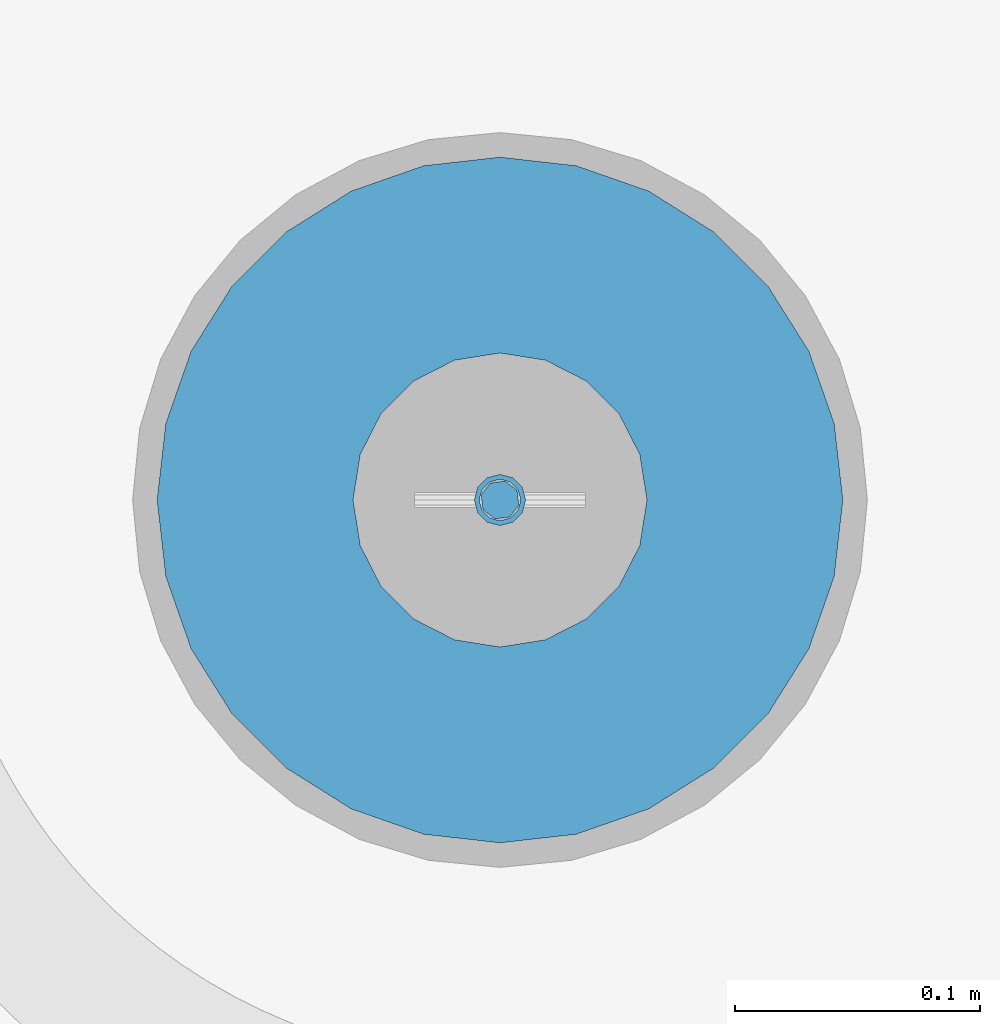
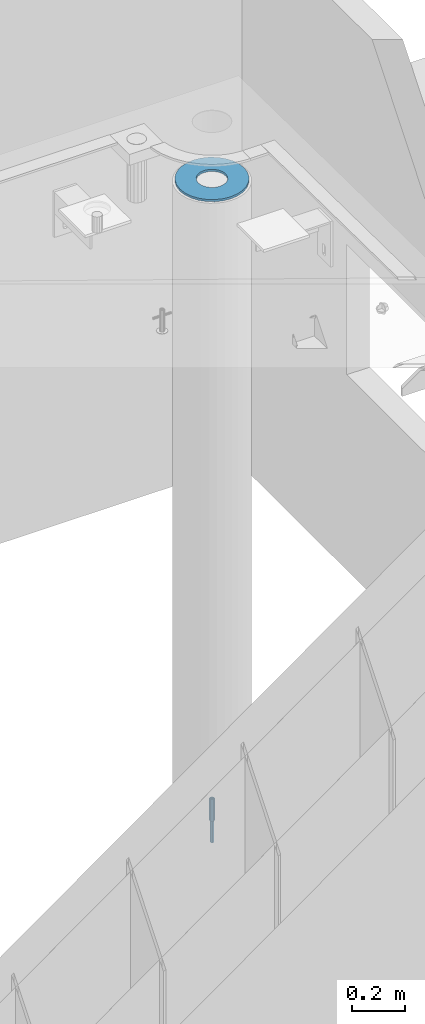
# One storey, part 23 of 264: 3 columns, 3 elements without a shape of their own.
"""IFC2X3 building model written with IfcOpenShell, lengths in millimetres."""

from ifc_helpers import new_model, si_unit, frame, origin_with_axes, place, context, subcontext, project, spatial, faceted_brep, material, type_object, element, aggregate, save


model = new_model("IFC2X3")

# Units and contexts
model_context = context("Model", 3, precision=1e-05, world=origin_with_axes())
body_context = subcontext(model_context, "Body", "Model", "MODEL_VIEW")
ifc_project = project(units=[si_unit("LENGTHUNIT", "METRE", prefix="MILLI"), si_unit("AREAUNIT", "SQUARE_METRE"), si_unit("VOLUMEUNIT", "CUBIC_METRE"), si_unit("MASSUNIT", "GRAM", prefix="KILO"), si_unit("TIMEUNIT", "SECOND"), si_unit("PLANEANGLEUNIT", "RADIAN"), si_unit("SOLIDANGLEUNIT", "STERADIAN"), si_unit("THERMODYNAMICTEMPERATUREUNIT", "DEGREE_CELSIUS"), si_unit("LUMINOUSINTENSITYUNIT", "LUMEN")], contexts=[model_context])

# Site, building, storey
site_placement = place(None, origin_with_axes())
site = spatial("IfcSite", under=ifc_project, at=site_placement, CompositionType="ELEMENT")
building_placement = place(site_placement, origin_with_axes())
building = spatial("IfcBuilding", under=site, at=building_placement, CompositionType="ELEMENT")
storey_placement = place(building_placement, origin_with_axes())
storey = spatial("IfcBuildingStorey", under=building, at=storey_placement, Name="K", CompositionType="ELEMENT", Elevation=0.0)

# Assemblies, columns
assembly_1_placement = place(storey_placement, origin_with_axes())
assembly_1 = element("IfcElementAssembly", 1, at=assembly_1_placement, inside=storey, AssemblyPlace="NOTDEFINED", PredefinedType="REINFORCEMENT_UNIT")
assembly_2_placement = place(assembly_1_placement, origin_with_axes())
assembly_2 = element("IfcElementAssembly", 2, at=assembly_2_placement, Name="Steel Assembly", AssemblyPlace="NOTDEFINED", PredefinedType="RIGID_FRAME")
ifc_material_1 = material(Name="STEEL/S235JR")
column_type_1 = type_object("IfcColumnType", Name="D16", PredefinedType="NOTDEFINED")
column_1_placement = place(assembly_2_placement, frame((35010.0004801435, 22669.9842012047, 78390.0), z_axis=(-0.261346946111888, -0.96524492941325, 0.0), x_axis=(0.0, 0.0, 1.0)))
column_1 = element("IfcColumn", 3, at=column_1_placement, type_object=column_type_1, material=ifc_material_1, Name="M16", ObjectType="D16", context=body_context, shape_type="Brep", body=[
    faceted_brep([(0.0, -8.0, 0.0), (0.0, -5.65685424949334, -5.65685424949334), (150.0, -5.65685424949697, -5.65685424949334), (150.0, -8.00000000000364, 0.0), (0.0, 0.0, -8.0), (150.0, -7.27595761418343e-12, -7.99999999999636), (0.0, 5.65685424949334, -5.65685424949334), (150.0, 5.6568542494897, -5.65685424949334), (0.0, 8.0, 0.0), (150.0, 8.0, -3.63797880709171e-12), (0.0, 5.65685424949334, 5.65685424949334), (150.0, 5.65685424949334, 5.65685424949697), (0.0, 0.0, 8.0), (150.0, -3.63797880709171e-12, 8.0), (0.0, -5.65685424949334, 5.65685424949334), (150.0, -5.65685424949334, 5.6568542494897)], [[[0, 1, 2, 3]], [[1, 4, 5, 2]], [[4, 6, 7, 5]], [[6, 8, 9, 7]], [[8, 10, 11, 9]], [[10, 12, 13, 11]], [[12, 14, 15, 13]], [[14, 0, 3, 15]], [[5, 7, 9, 11, 13, 15, 3, 2]], [[14, 12, 10, 8, 6, 4, 1, 0]]]),
])
aggregate(assembly_2, [column_1])
assembly_3_placement = place(assembly_1_placement, origin_with_axes())
assembly_3 = element("IfcElementAssembly", 4, at=assembly_3_placement, Name="Steel Assembly", AssemblyPlace="NOTDEFINED", PredefinedType="RIGID_FRAME")
ifc_material_2 = material(Name="STEEL/Steel_Undefined")
column_type_2 = type_object("IfcColumnType", PredefinedType="NOTDEFINED")
column_2_placement = place(assembly_3_placement, frame((35009.9987952044, 22669.984888838, 78490.0), z_axis=(0.0, 1.0, 0.0), x_axis=(0.0, 0.0, 1.0)))
column_2 = element("IfcColumn", 5, at=column_2_placement, type_object=column_type_2, material=ifc_material_2, context=body_context, shape_type="Brep", body=[
    faceted_brep([(0.0, -8.49999999999272, -1.45519152283669e-11), (0.0, -7.36121593215648, 4.24999999998545), (100.000000000262, -7.36121593215648, 4.24999999998545), (100.000000000262, -8.49999999999272, -1.45519152283669e-11), (0.0, -4.24999999998545, 7.36121593216376), (100.000000000262, -4.24999999998545, 7.36121593216376), (0.0, 1.45519152283669e-11, 8.49999999998545), (100.000000000262, 1.45519152283669e-11, 8.49999999998545), (0.0, 4.25000000001455, 7.36121593216376), (100.000000000262, 4.25000000001455, 7.36121593216376), (0.0, 7.36121593217104, 4.24999999998545), (100.000000000262, 7.36121593217104, 4.24999999998545), (0.0, 8.50000000000728, 0.0), (100.000000000262, 8.50000000000728, 0.0), (0.0, 7.36121593217104, -4.25000000001455), (100.000000000262, 7.36121593217104, -4.25000000001455), (0.0, 4.25000000000728, -7.36121593219286), (100.000000000262, 4.25000000000728, -7.36121593219286), (0.0, 7.27595761418343e-12, -8.5), (100.000000000262, 7.27595761418343e-12, -8.5), (0.0, -4.24999999999272, -7.36121593217831), (100.000000000262, -4.24999999999272, -7.36121593217831), (0.0, -7.36121593215648, -4.25), (100.000000000262, -7.36121593215648, -4.25), (0.0, -10.4999999999927, -1.45519152283669e-11), (0.0, -9.09326673972828, -5.25000000001455), (100.000000000262, -9.09326673972828, -5.25000000001455), (100.000000000262, -10.4999999999927, -1.45519152283669e-11), (0.0, -5.24999999998545, -9.09326673974283), (100.000000000262, -5.24999999998545, -9.09326673974283), (0.0, 7.27595761418343e-12, -10.5), (100.000000000262, 7.27595761418343e-12, -10.5), (0.0, 5.25000000001455, -9.09326673975738), (100.000000000262, 5.25000000001455, -9.09326673975738), (0.0, 9.09326673975011, -5.25000000001455), (100.000000000262, 9.09326673975011, -5.25000000001455), (0.0, 10.5000000000073, -1.45519152283669e-11), (100.000000000262, 10.5000000000073, -1.45519152283669e-11), (0.0, 9.09326673975011, 5.25), (100.000000000262, 9.09326673975011, 5.25), (0.0, 5.25000000000728, 9.09326673972828), (100.000000000262, 5.25000000000728, 9.09326673972828), (0.0, 1.45519152283669e-11, 10.4999999999854), (100.000000000262, 1.45519152283669e-11, 10.4999999999854), (0.0, -5.24999999999272, 9.09326673972828), (100.000000000262, -5.24999999999272, 9.09326673972828), (0.0, -9.09326673972828, 5.24999999998545), (100.000000000262, -9.09326673972828, 5.24999999998545)], [[[0, 1, 2, 3]], [[1, 4, 5, 2]], [[4, 6, 7, 5]], [[6, 8, 9, 7]], [[8, 10, 11, 9]], [[10, 12, 13, 11]], [[12, 14, 15, 13]], [[14, 16, 17, 15]], [[16, 18, 19, 17]], [[18, 20, 21, 19]], [[20, 22, 23, 21]], [[22, 0, 3, 23]], [[24, 25, 26, 27]], [[25, 28, 29, 26]], [[28, 30, 31, 29]], [[30, 32, 33, 31]], [[32, 34, 35, 33]], [[34, 36, 37, 35]], [[36, 38, 39, 37]], [[38, 40, 41, 39]], [[40, 42, 43, 41]], [[42, 44, 45, 43]], [[44, 46, 47, 45]], [[46, 24, 27, 47]], [[29, 31, 33, 35, 37, 39, 41, 43, 45, 47, 27, 26], [5, 7, 9, 11, 13, 15, 17, 19, 21, 23, 3, 2]], [[46, 44, 42, 40, 38, 36, 34, 32, 30, 28, 25, 24], [22, 20, 18, 16, 14, 12, 10, 8, 6, 4, 1, 0]]]),
])
aggregate(assembly_3, [column_2])
ifc_material_3 = material()
column_type_3 = type_object("IfcColumnType", Name="D280", PredefinedType="NOTDEFINED")
column_3_placement = place(assembly_1_placement, frame((35009.9987952044, 22669.984888838, 81435.0), z_axis=(-1.0, 3.00000001838171e-08, 0.0), x_axis=(0.0, 0.0, 1.0)))
column_3 = element("IfcColumn", 6, at=column_3_placement, type_object=column_type_3, material=ifc_material_3, Name="60", ObjectType="D280", context=body_context, shape_type="Brep", body=[
    faceted_brep([(10.0, -18.541019662498, -57.0633909777098), (0.0, -18.541019662498, -57.0633909777098), (0.0, -35.2671151375471, -48.5410196624944), (10.0, -35.2671151375471, -48.5410196624944), (0.0, -48.541019662498, -35.2671151375471), (10.0, -48.541019662498, -35.2671151375471), (0.0, -57.0633909777098, -18.5410196624944), (10.0, -57.0633909777098, -18.5410196624944), (0.0, -60.0, 0.0), (10.0, -60.0, 0.0), (0.0, -57.0633909777098, 18.5410196624944), (10.0, -57.0633909777098, 18.5410196624944), (0.0, -48.541019662498, 35.2671151375471), (10.0, -48.541019662498, 35.2671151375471), (0.0, -35.2671151375471, 48.5410196624944), (10.0, -35.2671151375471, 48.5410196624944), (0.0, -18.541019662498, 57.0633909777098), (10.0, -18.541019662498, 57.0633909777098), (0.0, 0.0, 60.0), (10.0, 0.0, 60.0), (0.0, 18.541019662498, 57.0633909777098), (10.0, 18.541019662498, 57.0633909777098), (0.0, 35.2671151375471, 48.5410196624944), (10.0, 35.2671151375471, 48.5410196624944), (0.0, 48.541019662498, 35.2671151375471), (10.0, 48.541019662498, 35.2671151375471), (0.0, 57.0633909777098, 18.5410196624944), (10.0, 57.0633909777098, 18.5410196624944), (0.0, 60.0, 0.0), (10.0, 60.0, 0.0), (0.0, 57.0633909777098, -18.5410196624944), (10.0, 57.0633909777098, -18.5410196624944), (0.0, 48.541019662498, -35.2671151375471), (10.0, 48.541019662498, -35.2671151375471), (0.0, 35.2671151375471, -48.5410196624944), (10.0, 35.2671151375471, -48.5410196624944), (0.0, 18.541019662498, -57.0633909777098), (10.0, 18.541019662498, -57.0633909777098), (0.0, 0.0, -60.0), (10.0, 0.0, -60.0), (0.0, -136.489907705454, -31.1529307538876), (0.0, -126.135641506338, -60.7437234764584), (10.0, -126.135641506338, -60.7437234764584), (10.0, -136.489907705454, -31.1529307538876), (0.0, -109.456407545524, -87.2885722602223), (10.0, -109.456407545524, -87.2885722602223), (0.0, -87.2885722602223, -109.456407545527), (10.0, -87.2885722602223, -109.456407545527), (0.0, -60.7437234764584, -126.135641506342), (10.0, -60.7437234764584, -126.135641506342), (0.0, -31.152930753884, -136.489907705458), (10.0, -31.152930753884, -136.489907705458), (0.0, 0.0, -140.0), (10.0, 0.0, -140.0), (0.0, 31.152930753884, -136.489907705458), (10.0, 31.152930753884, -136.489907705458), (0.0, 60.7437234764584, -126.135641506342), (10.0, 60.7437234764584, -126.135641506342), (0.0, 87.2885722602223, -109.456407545527), (10.0, 87.2885722602223, -109.456407545527), (0.0, 109.456407545524, -87.2885722602223), (10.0, 109.456407545524, -87.2885722602223), (0.0, 126.135641506338, -60.7437234764584), (10.0, 126.135641506338, -60.7437234764584), (0.0, 136.489907705454, -31.1529307538876), (10.0, 136.489907705454, -31.1529307538876), (0.0, 140.0, 0.0), (10.0, 140.0, 0.0), (0.0, 136.489907705454, 31.1529307538876), (10.0, 136.489907705454, 31.1529307538876), (0.0, 126.135641506338, 60.7437234764584), (10.0, 126.135641506338, 60.7437234764584), (0.0, 109.456407545524, 87.2885722602223), (10.0, 109.456407545524, 87.2885722602223), (0.0, 87.2885722602223, 109.456407545527), (10.0, 87.2885722602223, 109.456407545527), (0.0, 60.7437234764584, 126.135641506342), (10.0, 60.7437234764584, 126.135641506342), (0.0, 31.152930753884, 136.489907705458), (10.0, 31.152930753884, 136.489907705458), (0.0, 0.0, 140.0), (10.0, 0.0, 140.0), (0.0, -31.152930753884, 136.489907705458), (10.0, -31.152930753884, 136.489907705458), (0.0, -60.7437234764584, 126.135641506342), (10.0, -60.7437234764584, 126.135641506342), (0.0, -87.2885722602223, 109.456407545527), (10.0, -87.2885722602223, 109.456407545527), (0.0, -109.456407545524, 87.2885722602223), (10.0, -109.456407545524, 87.2885722602223), (0.0, -126.135641506338, 60.7437234764584), (10.0, -126.135641506338, 60.7437234764584), (0.0, -136.489907705454, 31.1529307538876), (10.0, -136.489907705454, 31.1529307538876), (0.0, -140.0, 0.0), (10.0, -140.0, 0.0)], [[[0, 1, 2, 3]], [[3, 2, 4, 5]], [[5, 4, 6, 7]], [[7, 6, 8, 9]], [[9, 8, 10, 11]], [[11, 10, 12, 13]], [[13, 12, 14, 15]], [[15, 14, 16, 17]], [[17, 16, 18, 19]], [[19, 18, 20, 21]], [[21, 20, 22, 23]], [[23, 22, 24, 25]], [[25, 24, 26, 27]], [[27, 26, 28, 29]], [[29, 28, 30, 31]], [[31, 30, 32, 33]], [[33, 32, 34, 35]], [[35, 34, 36, 37]], [[37, 36, 38, 39]], [[39, 38, 1, 0]], [[40, 41, 42, 43]], [[41, 44, 45, 42]], [[44, 46, 47, 45]], [[46, 48, 49, 47]], [[48, 50, 51, 49]], [[50, 52, 53, 51]], [[52, 54, 55, 53]], [[54, 56, 57, 55]], [[56, 58, 59, 57]], [[58, 60, 61, 59]], [[60, 62, 63, 61]], [[62, 64, 65, 63]], [[64, 66, 67, 65]], [[66, 68, 69, 67]], [[68, 70, 71, 69]], [[70, 72, 73, 71]], [[72, 74, 75, 73]], [[74, 76, 77, 75]], [[76, 78, 79, 77]], [[78, 80, 81, 79]], [[80, 82, 83, 81]], [[82, 84, 85, 83]], [[84, 86, 87, 85]], [[86, 88, 89, 87]], [[88, 90, 91, 89]], [[90, 92, 93, 91]], [[92, 94, 95, 93]], [[42, 45, 47, 49, 51, 53, 55, 57, 59, 61, 63, 65, 67, 69, 71, 73, 75, 77, 79, 81, 83, 85, 87, 89, 91, 93, 95, 43], [3, 5, 7, 9, 11, 13, 15, 17, 19, 21, 23, 25, 27, 29, 31, 33, 35, 37, 39, 0]], [[94, 40, 43, 95]], [[92, 90, 88, 86, 84, 82, 80, 78, 76, 74, 72, 70, 68, 66, 64, 62, 60, 58, 56, 54, 52, 50, 48, 46, 44, 41, 40, 94], [34, 32, 30, 28, 26, 24, 22, 20, 18, 16, 14, 12, 10, 8, 6, 4, 2, 1, 38, 36]]]),
])
aggregate(assembly_1, [assembly_3, assembly_2, column_3])

save(model, "model.ifc")
